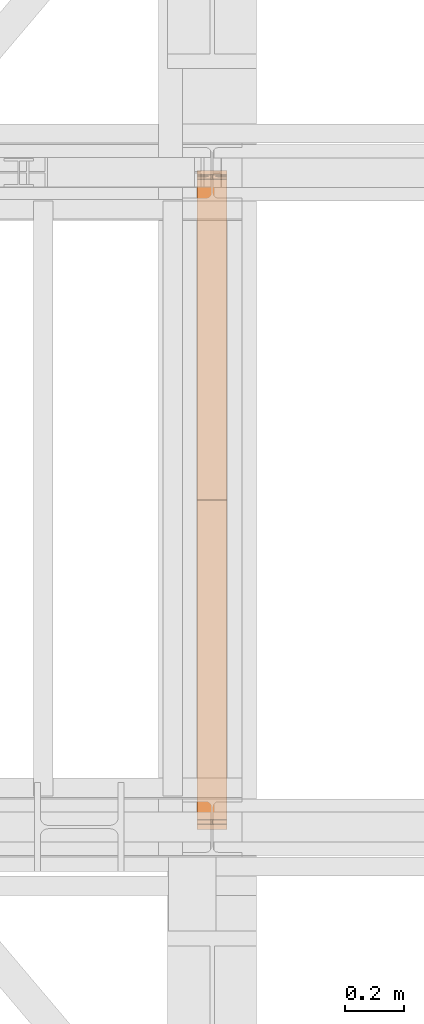
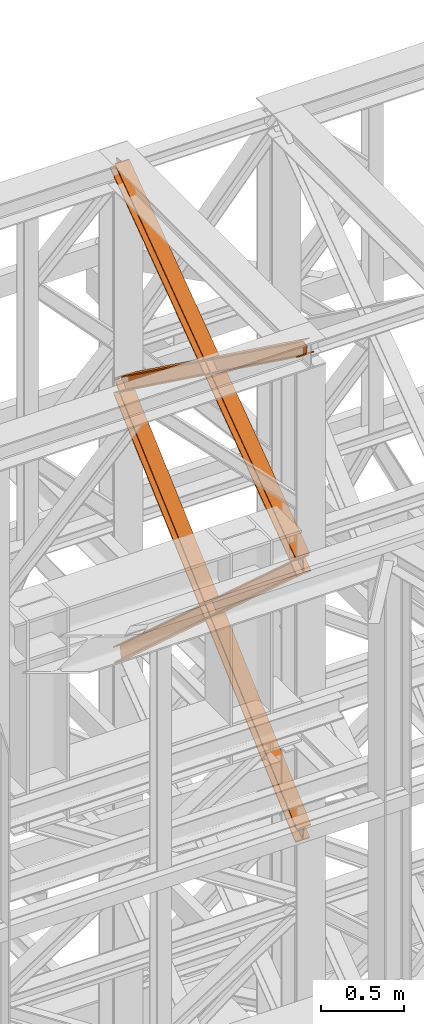
# One storey, part 158 of 208: 4 proxies.
"""IFC2X3 building model written with IfcOpenShell, lengths in millimetres."""

from ifc_helpers import new_model, entity, si_unit, converted_unit, frame, origin, origin_with_axes, place, context, subcontext, project, spatial, faceted_brep, element, save


model = new_model("IFC2X3")

# Units and contexts
model_context = context("Model", 3, precision=1e-05, world=origin())
plan_context = context("Plan", 3, precision=1e-05, world=origin())
body_context = subcontext(model_context, "Body", "Model", "MODEL_VIEW")
ifc_project = project(units=[si_unit("LENGTHUNIT", "METRE", prefix="MILLI"), converted_unit("PLANEANGLEUNIT", "DEGREE", entity("IfcPlaneAngleMeasure", 0.0174532925199433), si_unit("PLANEANGLEUNIT", "RADIAN"), dimensions=[0, 0, 0, 0, 0, 0, 0]), si_unit("AREAUNIT", "SQUARE_METRE"), si_unit("VOLUMEUNIT", "CUBIC_METRE")], contexts=[model_context, plan_context])

# Building, storey
building_placement = place(None, origin())
building = spatial("IfcBuilding", under=ifc_project, at=building_placement, CompositionType="COMPLEX")
storey_placement = place(building_placement, origin_with_axes())
storey = spatial("IfcBuildingStorey", under=building, at=storey_placement, Name="Geschoss", CompositionType="ELEMENT")

# Proxies
proxy_1_placement = place(storey_placement, frame((5442.709402308909, -16015.63876149258, 10682.68948145022), z_axis=(0.0, 0.0, 1.0), x_axis=(1.0, 0.0, 0.0)))
element("IfcBuildingElementProxy", 1, at=proxy_1_placement, inside=storey, context=body_context, shape_type="Brep", body=[
    faceted_brep([(100.0210796676656, 2245.689626284609, 118.5389832593155), (100.1143745484151, 56.20017042807194, 1708.580236273849), (100.1148393871226, 67.43957130666058, 1710.120789741106), (100.0220869572258, 2244.212677303514, 129.3143453983157), (100.0220869572258, 2244.212677303514, 129.3143453983157), (100.1148393871226, 67.43957130666058, 1710.120789741106), (0.1148394121519232, 67.45274636205431, 1710.122490249456), (0.02208754364073684, 2244.212677303513, 129.3256138365559), (0.02208754364073684, 2244.212677303513, 129.3256138365559), (0.1148394121519232, 67.45274636205431, 1710.122490249456), (0.1143745734407275, 56.21334548348023, 1708.581936782199), (0.02108025408597314, 2245.689626284609, 118.5502516975485), (0.02108025408597314, 2245.689626284609, 118.5502516975485), (0.1143745734407275, 56.21334548348023, 1708.581936782199), (47.61437456155181, 56.20708733215906, 1708.581129040735), (47.52107997553685, 2245.689626284611, 118.5448991893809), (47.52107997553685, 2245.689626284611, 118.5448991893809), (47.61437456155181, 56.20708733215906, 1708.581129040735), (47.61205046476789, 0.010082544398756, 1700.878361650326), (47.60701710203466, 7.394829104428936, 1647.001538883871), (47.51100702250551, 2260.459116064767, 10.79127802407129), (47.51100702250551, 2260.459116064767, 10.79127802407129), (47.60701710203466, 7.394829104428936, 1647.001538883871), (0.107017380585603, 7.394829104430755, 1647.006891392024), (0.01100730106008996, 2260.459116064769, 10.79663053222066), (0.01100730106008996, 2260.459116064769, 10.79663053222066), (0.107017380585603, 7.394829104430755, 1647.006891392024), (0.1060107062494353, 8.871778415476001, 1636.231526845748), (0.01000000000021828, 2261.936065039698, 0.02126843821861257), (0.01000000000021828, 2261.936065039698, 0.02126843821861257), (0.1060107062494353, 8.871778415476001, 1636.231526845748), (100.1060101198273, 8.871778415472363, 1636.220258407533), (100.0099994135744, 2261.936065039694, 0.01000000000021828), (100.0099994135744, 2261.936065039694, 0.01000000000021828), (100.1060101198273, 8.871778415472363, 1636.220258407533), (100.1070167941634, 7.394829104425298, 1646.995622953813), (100.0110067146379, 2260.459116064765, 10.78536209401318), (100.0110067146379, 2260.459116064765, 10.78536209401318), (100.1070167941634, 7.394829104425298, 1646.995622953813), (52.60701707271619, 7.394829104428936, 1647.000975461962), (52.51100699318704, 2260.459116064767, 10.79071460216255), (52.51100699318704, 2260.459116064767, 10.79071460216255), (52.60701707271619, 7.394829104428936, 1647.000975461962), (52.61205048734519, 0.01000000000021828, 1700.878355604191), (52.61437456030035, 56.20642857939311, 1708.581044015316), (52.52107994621292, 2245.689626284609, 118.5443357674758), (52.52107994621292, 2245.689626284609, 118.5443357674758), (52.61437456030035, 56.20642857939311, 1708.581044015316), (100.1143745484151, 56.20017042807194, 1708.580236273849), (100.0210796676656, 2245.689626284609, 118.5389832593155), (100.1143745484151, 56.20017042807194, 1708.580236273849), (52.61437456030035, 56.20642857939311, 1708.581044015316), (52.61205048734519, 0.01000000000021828, 1700.878355604191), (47.61205046476789, 0.010082544398756, 1700.878361650326), (47.61437456155181, 56.20708733215906, 1708.581129040735), (0.1143745734407275, 56.21334548348023, 1708.581936782199), (0.1148394121519232, 67.45274636205431, 1710.122490249456), (100.1148393871226, 67.43957130666058, 1710.120789741106), (47.61205046476789, 0.010082544398756, 1700.878361650326), (52.61205048734519, 0.01000000000021828, 1700.878355604191), (52.60701707271619, 7.394829104428936, 1647.000975461962), (100.1070167941634, 7.394829104425298, 1646.995622953813), (100.1060101198273, 8.871778415472363, 1636.220258407533), (0.1060107062494353, 8.871778415476001, 1636.231526845748), (0.107017380585603, 7.394829104430755, 1647.006891392024), (47.60701710203466, 7.394829104428936, 1647.001538883871), (100.0220869572258, 2244.212677303514, 129.3143453983157), (0.02208754364073684, 2244.212677303513, 129.3256138365559), (0.02108025408597314, 2245.689626284609, 118.5502516975485), (47.52107997553685, 2245.689626284611, 118.5448991893809), (47.51100702250551, 2260.459116064767, 10.79127802407129), (0.01100730106008996, 2260.459116064769, 10.79663053222066), (0.01000000000021828, 2261.936065039698, 0.02126843821861257), (100.0099994135744, 2261.936065039694, 0.01000000000021828), (100.0110067146379, 2260.459116064765, 10.78536209401318), (52.51100699318704, 2260.459116064767, 10.79071460216255), (52.52107994621292, 2245.689626284609, 118.5443357674758), (100.0210796676656, 2245.689626284609, 118.5389832593155)], [[[0, 1, 2, 3]], [[4, 5, 6, 7]], [[8, 9, 10, 11]], [[12, 13, 14, 15]], [[16, 17, 18, 19, 20]], [[21, 22, 23, 24]], [[25, 26, 27, 28]], [[29, 30, 31, 32]], [[33, 34, 35, 36]], [[37, 38, 39, 40]], [[41, 42, 43, 44, 45]], [[46, 47, 48, 49]], [[50, 51, 52, 53, 54, 55, 56, 57]], [[58, 59, 60, 61, 62, 63, 64, 65]], [[66, 67, 68, 69, 70, 71, 72, 73, 74, 75, 76, 77]]], orient=[[False], [False], [False], [False], [False], [False], [False], [False], [False], [False], [False], [False], [False], [False], [False]]),
])
proxy_2_placement = place(storey_placement, frame((5442.729181833694, -15971.44366069647, 10682.68296591904), z_axis=(0.0, 0.0, 1.0), x_axis=(1.0, 0.0, 0.0)))
element("IfcBuildingElementProxy", 2, at=proxy_2_placement, inside=storey, context=body_context, shape_type="Brep", body=[
    faceted_brep([(100.0217932552368, 17.74853331263148, 129.3267546407205), (100.0912677831911, 2190.182945540866, 1706.987836358048), (100.0906922275608, 2201.421092011329, 1705.446286432978), (100.0208104383473, 16.27032220023102, 118.5503583986774), (0.02179387014803069, 17.74853331263148, 129.3386776252864), (0.09126795233532903, 2190.169006714281, 1706.989636715169), (100.0912677831911, 2190.182945540866, 1706.987836358048), (100.0217932552368, 17.74853331263148, 129.3267546407205), (0.0208110532585124, 16.27032220022738, 118.5622813832288), (0.09069239670316165, 2201.407153184735, 1705.448086790095), (0.09126795233532903, 2190.169006714281, 1706.989636715169), (0.02179387014803069, 17.74853331263148, 129.3386776252864), (47.52081076117611, 16.2703222002292, 118.5566179655598), (47.59069231636022, 2201.413774127363, 1705.447231620465), (0.09069239670316165, 2201.407153184735, 1705.448086790095), (0.0208110532585124, 16.27032220022738, 118.5622813832288), (47.51098253605778, 1.488211106367089, 10.79265576491343), (47.58304941302777, 2254.773823250514, 1647.169314498546), (47.58760831105064, 2261.634760381639, 1697.186647271237), (47.59069231636022, 2201.413774127363, 1705.447231620465), (47.52081076117611, 16.2703222002292, 118.5566179655598), (0.01098282814200502, 1.488211106363451, 10.79831918255331), (0.08304970511198917, 2254.773823250511, 1647.174977916204), (47.58304941302777, 2254.773823250514, 1647.169314498546), (47.51098253605778, 1.488211106367089, 10.79265576491343), (0.01000000000021828, 0.01000000000021828, 0.02192298452973773), (0.08206748974225775, 2253.295611815232, 1636.398579320261), (0.08304970511198917, 2254.773823250511, 1647.174977916204), (0.01098282814200502, 1.488211106363451, 10.79831918255331), (100.0099993850836, 0.01000000000567525, 0.01000000000021828), (100.0820668748293, 2253.29561181524, 1636.386656335728), (0.08206748974225775, 2253.295611815232, 1636.398579320261), (0.01000000000021828, 0.01000000000021828, 0.02192298452973773), (100.010982213229, 1.488211106370727, 10.78639619803107), (100.0830490901917, 2254.773823250516, 1647.163054931671), (100.0820668748293, 2253.29561181524, 1636.386656335728), (100.0099993850836, 0.01000000000567525, 0.01000000000021828), (52.51098250530595, 1.48821110636527, 10.79205961566731), (52.58304938227957, 2254.773823250514, 1647.168718349318), (100.0830490901917, 2254.773823250516, 1647.163054931671), (100.010982213229, 1.488211106370727, 10.78639619803107), (52.52081073042791, 16.27032220022738, 118.5560218163319), (52.59069230790374, 2201.414471068691, 1705.447141602608), (52.58760833413726, 2261.634841397497, 1697.186641740611), (52.58304938227957, 2254.773823250514, 1647.168718349318), (52.51098250530595, 1.48821110636527, 10.79205961566731), (100.0208104383473, 16.27032220023102, 118.5503583986774), (100.0906922275608, 2201.421092011329, 1705.446286432978), (52.59069230790374, 2201.414471068691, 1705.447141602608), (52.52081073042791, 16.27032220022738, 118.5560218163319), (100.0912677831911, 2190.182945540866, 1706.987836358048), (0.09126795233532903, 2190.169006714281, 1706.989636715169), (0.09069239670316165, 2201.407153184735, 1705.448086790095), (47.59069231636022, 2201.413774127363, 1705.447231620465), (47.58760831105064, 2261.634760381639, 1697.186647271237), (52.58760833413726, 2261.634841397497, 1697.186641740611), (52.59069230790374, 2201.414471068691, 1705.447141602608), (100.0906922275608, 2201.421092011329, 1705.446286432978), (47.58760831105064, 2261.634760381639, 1697.186647271237), (47.58304941302777, 2254.773823250514, 1647.169314498546), (0.08304970511198917, 2254.773823250511, 1647.174977916204), (0.08206748974225775, 2253.295611815232, 1636.398579320261), (100.0820668748293, 2253.29561181524, 1636.386656335728), (100.0830490901917, 2254.773823250516, 1647.163054931671), (52.58304938227957, 2254.773823250514, 1647.168718349318), (52.58760833413726, 2261.634841397497, 1697.186641740611), (100.0208104383473, 16.27032220023102, 118.5503583986774), (52.52081073042791, 16.27032220022738, 118.5560218163319), (52.51098250530595, 1.48821110636527, 10.79205961566731), (100.010982213229, 1.488211106370727, 10.78639619803107), (100.0099993850836, 0.01000000000567525, 0.01000000000021828), (0.01000000000021828, 0.01000000000021828, 0.02192298452973773), (0.01098282814200502, 1.488211106363451, 10.79831918255331), (47.51098253605778, 1.488211106367089, 10.79265576491343), (47.52081076117611, 16.2703222002292, 118.5566179655598), (0.0208110532585124, 16.27032220022738, 118.5622813832288), (0.02179387014803069, 17.74853331263148, 129.3386776252864), (100.0217932552368, 17.74853331263148, 129.3267546407205)], [[[0, 1, 2, 3]], [[4, 5, 6, 7]], [[8, 9, 10, 11]], [[12, 13, 14, 15]], [[16, 17, 18, 19, 20]], [[21, 22, 23, 24]], [[25, 26, 27, 28]], [[29, 30, 31, 32]], [[33, 34, 35, 36]], [[37, 38, 39, 40]], [[41, 42, 43, 44, 45]], [[46, 47, 48, 49]], [[50, 51, 52, 53, 54, 55, 56, 57]], [[58, 59, 60, 61, 62, 63, 64, 65]], [[66, 67, 68, 69, 70, 71, 72, 73, 74, 75, 76, 77]]], orient=[[False], [False], [False], [False], [False], [False], [False], [False], [False], [False], [False], [False], [False], [False], [False]]),
])
proxy_3_placement = place(storey_placement, frame((5442.676947659522, -15970.94025142175, 8709.664099392032), z_axis=(0.0, 0.0, 1.0), x_axis=(1.0, 0.0, 0.0)))
element("IfcBuildingElementProxy", 3, at=proxy_3_placement, inside=storey, context=body_context, shape_type="Brep", body=[
    faceted_brep([(100.0233874223195, 2202.524047252906, 1969.026231437971), (100.204135948361, 16.74193427489081, 0.02100513656296243), (100.2031119106669, 15.34760641933463, 9.331797992270367), (100.0223627570795, 2201.129719715085, 1978.337022171885), (0.02338802788472094, 2202.524047252906, 1969.015226301408), (0.2041365539262188, 16.74193427489081, 0.01000000000021828), (100.204135948361, 16.74193427489081, 0.02100513656296243), (100.0233874223195, 2202.524047252906, 1969.026231437971), (0.02236336264650163, 2201.129719715083, 1978.32601703533), (0.2031125162320677, 15.34760641933463, 9.320792855700347), (0.2041365539262188, 16.74193427489081, 0.01000000000021828), (0.02338802788472094, 2202.524047252906, 1969.015226301408), (47.52236307500243, 2201.129719715083, 1978.331244475192), (47.703112228588, 15.34760641933463, 9.326020295562557), (0.2031125162320677, 15.34760641933463, 9.320792855700347), (0.02236336264650163, 2201.129719715083, 1978.32601703533), (47.51211642258568, 2187.186444336861, 2071.439151814395), (47.69287186516885, 1.404327856926102, 102.4339488982641), (47.703112228588, 15.34760641933463, 9.326020295562557), (47.52236307500243, 2201.129719715083, 1978.331244475192), (0.0110594602265337, 2197.850904391578, 2081.040801967907), (0.01123343514518638, 2196.096022801514, 2079.459950003524), (29.30670605184969, 2196.096022801514, 2079.463174010305), (38.62248918838486, 2197.75725418804, 2080.960688188874), (38.72759933923771, 2197.85090439158, 2081.04506277602), (47.51211642258568, 2187.186444336861, 2071.439151814395), (0.0121167102297477, 2187.186444336861, 2071.433924374533), (0.1928721528147435, 1.404327856924283, 102.4287214583947), (47.69287186516885, 1.404327856926102, 102.4339488982641), (0.01000000000021828, 2196.807553171771, 2090.667763094707), (0.01020876990332909, 2194.701695263691, 2088.770740737438), (0.01123343514518638, 2196.096022801514, 2079.459950003524), (0.0110594602265337, 2197.850904391578, 2081.040801967907), (0.0121167102297477, 2187.186444336861, 2071.433924374533), (0.01109204498970939, 2185.792116799039, 2080.744715108447), (0.1918481178254297, 0.00999999999839929, 111.7395143232407), (0.1928721528147435, 1.404327856924283, 102.4287214583947), (100.0099993944386, 2196.80755317177, 2090.67876823127), (100.0102081643418, 2194.701695263691, 2088.781745874001), (71.80672165016404, 2194.701695263691, 2088.778642041782), (62.49088072881023, 2196.362926650216, 2090.274105784663), (61.99182992716487, 2196.80755317177, 2090.674584279774), (0.01109204498970939, 2185.792116799039, 2080.744715108447), (100.0110914394281, 2185.792116799039, 2080.755720245017), (100.1918475122639, 0.00999999999839929, 111.7505194598034), (0.1918481178254297, 0.00999999999839929, 111.7395143232407), (0.01020876990332909, 2194.701695263691, 2088.770740737438), (0.01000000000021828, 2196.807553171771, 2090.667763094707), (39.12153594998199, 2196.807553171771, 2090.672067372672), (38.62250061437408, 2196.362926650216, 2090.271479036817), (29.3067174778389, 2194.701695263691, 2088.773964858256), (100.0110588546631, 2197.85090439158, 2081.051807104463), (100.01123282958, 2196.096022801514, 2079.470955140079), (100.0102081643418, 2194.701695263691, 2088.781745874001), (100.0099993944386, 2196.80755317177, 2090.67876823127), (100.0110914394281, 2185.792116799039, 2080.755720245017), (100.0121161046682, 2187.186444336861, 2071.444929511088), (100.1928715472459, 1.404327856926102, 102.4397265949574), (100.1918475122639, 0.00999999999839929, 111.7505194598034), (52.5121163923086, 2187.186444336861, 2071.439702071226), (52.69287183489359, 1.404327856924283, 102.4344991550879), (100.1928715472459, 1.404327856926102, 102.4397265949574), (100.0121161046682, 2187.186444336861, 2071.444929511088), (71.80671022417482, 2196.096022801516, 2079.467851193831), (100.01123282958, 2196.096022801514, 2079.470955140079), (100.0110588546631, 2197.85090439158, 2081.051807104463), (62.38575589440734, 2197.85090439158, 2081.047666388475), (62.49086930282101, 2197.75725418804, 2080.963314936713), (52.52236304472172, 2201.129719715083, 1978.331794732023), (52.7031121983091, 15.34760641933463, 9.326570552393605), (52.69287183489359, 1.404327856924283, 102.4344991550879), (52.5121163923086, 2187.186444336861, 2071.439702071226), (100.0223627570795, 2201.129719715085, 1978.337022171885), (100.2031119106669, 15.34760641933463, 9.331797992270367), (52.7031121983091, 15.34760641933463, 9.326570552393605), (52.52236304472172, 2201.129719715083, 1978.331794732023), (62.38575589440734, 2197.85090439158, 2081.047666388475), (100.0110588546631, 2197.85090439158, 2081.051807104463), (100.0099993944386, 2196.80755317177, 2090.67876823127), (61.99182992716487, 2196.80755317177, 2090.674584279774), (39.12153594998199, 2196.807553171771, 2090.672067372672), (0.01000000000021828, 2196.807553171771, 2090.667763094707), (0.0110594602265337, 2197.850904391578, 2081.040801967907), (38.72759933923771, 2197.85090439158, 2081.04506277602), (62.49086930282101, 2197.75725418804, 2080.963314936713), (62.38575589440734, 2197.85090439158, 2081.047666388475), (61.99182992716487, 2196.80755317177, 2090.674584279774), (62.49088072881023, 2196.362926650216, 2090.274105784663), (62.49088072881023, 2196.362926650216, 2090.274105784663), (71.80672165016404, 2194.701695263691, 2088.778642041782), (71.80671022417482, 2196.096022801516, 2079.467851193831), (62.49086930282101, 2197.75725418804, 2080.963314936713), (71.80672165016404, 2194.701695263691, 2088.778642041782), (100.0102081643418, 2194.701695263691, 2088.781745874001), (100.01123282958, 2196.096022801514, 2079.470955140079), (71.80671022417482, 2196.096022801516, 2079.467851193831), (100.0223627570795, 2201.129719715085, 1978.337022171885), (52.52236304472172, 2201.129719715083, 1978.331794732023), (52.5121163923086, 2187.186444336861, 2071.439702071226), (100.0121161046682, 2187.186444336861, 2071.444929511088), (100.0110914394281, 2185.792116799039, 2080.755720245017), (0.01109204498970939, 2185.792116799039, 2080.744715108447), (0.0121167102297477, 2187.186444336861, 2071.433924374533), (47.51211642258568, 2187.186444336861, 2071.439151814395), (47.52236307500243, 2201.129719715083, 1978.331244475192), (0.02236336264650163, 2201.129719715083, 1978.32601703533), (0.02338802788472094, 2202.524047252906, 1969.015226301408), (100.0233874223195, 2202.524047252906, 1969.026231437971), (29.30670605184969, 2196.096022801514, 2079.463174010305), (0.01123343514518638, 2196.096022801514, 2079.459950003524), (0.01020876990332909, 2194.701695263691, 2088.770740737438), (29.3067174778389, 2194.701695263691, 2088.773964858256), (29.3067174778389, 2194.701695263691, 2088.773964858256), (38.62250061437408, 2196.362926650216, 2090.271479036817), (38.62248918838486, 2197.75725418804, 2080.960688188874), (29.30670605184969, 2196.096022801514, 2079.463174010305), (38.62250061437408, 2196.362926650216, 2090.271479036817), (39.12153594998199, 2196.807553171771, 2090.672067372672), (38.72759933923771, 2197.85090439158, 2081.04506277602), (38.62248918838486, 2197.75725418804, 2080.960688188874), (100.204135948361, 16.74193427489081, 0.02100513656296243), (0.2041365539262188, 16.74193427489081, 0.01000000000021828), (0.2031125162320677, 15.34760641933463, 9.320792855700347), (47.703112228588, 15.34760641933463, 9.326020295562557), (47.69287186516885, 1.404327856926102, 102.4339488982641), (0.1928721528147435, 1.404327856924283, 102.4287214583947), (0.1918481178254297, 0.00999999999839929, 111.7395143232407), (100.1918475122639, 0.00999999999839929, 111.7505194598034), (100.1928715472459, 1.404327856926102, 102.4397265949574), (52.69287183489359, 1.404327856924283, 102.4344991550879), (52.7031121983091, 15.34760641933463, 9.326570552393605), (100.2031119106669, 15.34760641933463, 9.331797992270367)], [[[0, 1, 2, 3]], [[4, 5, 6, 7]], [[8, 9, 10, 11]], [[12, 13, 14, 15]], [[16, 17, 18, 19]], [[20, 21, 22, 23, 24]], [[25, 26, 27, 28]], [[29, 30, 31, 32]], [[33, 34, 35, 36]], [[37, 38, 39, 40, 41]], [[42, 43, 44, 45]], [[46, 47, 48, 49, 50]], [[51, 52, 53, 54]], [[55, 56, 57, 58]], [[59, 60, 61, 62]], [[63, 64, 65, 66, 67]], [[68, 69, 70, 71]], [[72, 73, 74, 75]], [[76, 77, 78, 79]], [[80, 81, 82, 83]], [[84, 85, 86, 87]], [[88, 89, 90, 91]], [[92, 93, 94, 95]], [[96, 97, 98, 99, 100, 101, 102, 103, 104, 105, 106, 107]], [[108, 109, 110, 111]], [[112, 113, 114, 115]], [[116, 117, 118, 119]], [[120, 121, 122, 123, 124, 125, 126, 127, 128, 129, 130, 131]]], orient=[[False], [False], [False], [False], [False], [False], [False], [False], [False], [False], [False], [False], [False], [False], [False], [False], [False], [False], [False], [False], [False], [False], [False], [False], [False], [False], [False], [False]]),
])
proxy_4_placement = place(storey_placement, frame((5442.73408746112, -15954.28145682049, 8709.631705441292), z_axis=(0.0, 0.0, 1.0), x_axis=(1.0, 0.0, 0.0)))
element("IfcBuildingElementProxy", 4, at=proxy_4_placement, inside=storey, context=body_context, shape_type="Brep", body=[
    faceted_brep([(100.0202537490113, 1.404418357440591, 1976.169685278082), (100.1537894349167, 2184.74959498962, 9.331916248220296), (100.1547211341531, 2183.35672227913, 0.0197810693334759), (100.0211859525844, 0.01154596052219858, 1966.857552195595), (100.0211859525844, 0.01154596052219858, 1966.857552195595), (100.1547211341531, 2183.35672227913, 0.0197810693334759), (0.1547216244507581, 2183.355176318608, 0.01000000000021828), (0.02118644288202631, 0.01000000000021828, 1966.847771126266), (0.02118644288202631, 0.01000000000021828, 1966.847771126266), (0.1547216244507581, 2183.355176318608, 0.01000000000021828), (0.1537899252161878, 2184.748049029098, 9.322135178887038), (0.02025423930899706, 1.40287239691861, 1976.159904208749), (0.02025423930899706, 1.40287239691861, 1976.159904208749), (0.1537899252161878, 2184.748049029098, 9.322135178887038), (47.65378969232734, 2184.748783360346, 9.326781186826338), (47.52025400642015, 1.403606728164959, 1976.164550216681), (47.52025400642015, 1.403606728164959, 1976.164550216681), (47.65378969232734, 2184.748783360346, 9.326781186826338), (47.64447271073732, 2198.677510471935, 102.4481330204089), (47.51093197068258, 15.33233069734524, 2069.285881041526), (47.51093197068258, 15.33233069734524, 2069.285881041526), (47.64447271073732, 2198.677510471935, 102.4481330204089), (0.1444729436279886, 2198.676776140686, 102.4434870124769), (0.01093220357506652, 15.33159636609526, 2069.281235033586), (0.01093220357506652, 15.33159636609526, 2069.281235033586), (0.1444729436279886, 2198.676776140686, 102.4434870124769), (0.1435412465452828, 2200.069648852516, 111.7556222003168), (0.01000000000021828, 16.72446876301547, 2078.593368116077), (0.01000000000021828, 16.72446876301547, 2078.593368116077), (0.1435412465452828, 2200.069648852516, 111.7556222003168), (100.1435407562476, 2200.071194813039, 111.7654032696537), (100.0099995097044, 16.72601472353745, 2078.603149185414), (100.0099995097044, 16.72601472353745, 2078.603149185414), (100.1435407562476, 2200.071194813039, 111.7654032696537), (100.1444724533303, 2198.67832210121, 102.4532680818102), (100.0109317132756, 15.33314232661905, 2069.29101610293), (100.0109317132756, 15.33314232661905, 2069.29101610293), (100.1444724533303, 2198.67832210121, 102.4532680818102), (52.64447268622098, 2198.677587769962, 102.4486220738781), (52.51093194616988, 15.33240799537089, 2069.286370094991), (52.51093194616988, 15.33240799537089, 2069.286370094991), (52.64447268622098, 2198.677587769962, 102.4486220738781), (52.653789667811, 2184.748860658372, 9.327270240288271), (52.52025398190563, 1.403684026192423, 1976.165039270154), (52.52025398190563, 1.403684026192423, 1976.165039270154), (52.653789667811, 2184.748860658372, 9.327270240288271), (100.1537894349167, 2184.74959498962, 9.331916248220296), (100.0202537490113, 1.404418357440591, 1976.169685278082), (100.0211859525844, 0.01154596052219858, 1966.857552195595), (0.02118644288202631, 0.01000000000021828, 1966.847771126266), (0.02025423930899706, 1.40287239691861, 1976.159904208749), (47.52025400642015, 1.403606728164959, 1976.164550216681), (47.51093197068258, 15.33233069734524, 2069.285881041526), (0.01093220357506652, 15.33159636609526, 2069.281235033586), (0.01000000000021828, 16.72446876301547, 2078.593368116077), (100.0099995097044, 16.72601472353745, 2078.603149185414), (100.0109317132756, 15.33314232661905, 2069.29101610293), (52.51093194616988, 15.33240799537089, 2069.286370094991), (52.52025398190563, 1.403684026192423, 1976.165039270154), (100.0202537490113, 1.404418357440591, 1976.169685278082), (100.1537894349167, 2184.74959498962, 9.331916248220296), (52.653789667811, 2184.748860658372, 9.327270240288271), (52.64447268622098, 2198.677587769962, 102.4486220738781), (100.1444724533303, 2198.67832210121, 102.4532680818102), (100.1435407562476, 2200.071194813039, 111.7654032696537), (0.1435412465452828, 2200.069648852516, 111.7556222003168), (0.1444729436279886, 2198.676776140686, 102.4434870124769), (47.64447271073732, 2198.677510471935, 102.4481330204089), (47.65378969232734, 2184.748783360346, 9.326781186826338), (0.1537899252161878, 2184.748049029098, 9.322135178887038), (0.1547216244507581, 2183.355176318608, 0.01000000000021828), (100.1547211341531, 2183.35672227913, 0.0197810693334759)], [[[0, 1, 2, 3]], [[4, 5, 6, 7]], [[8, 9, 10, 11]], [[12, 13, 14, 15]], [[16, 17, 18, 19]], [[20, 21, 22, 23]], [[24, 25, 26, 27]], [[28, 29, 30, 31]], [[32, 33, 34, 35]], [[36, 37, 38, 39]], [[40, 41, 42, 43]], [[44, 45, 46, 47]], [[48, 49, 50, 51, 52, 53, 54, 55, 56, 57, 58, 59]], [[60, 61, 62, 63, 64, 65, 66, 67, 68, 69, 70, 71]]], orient=[[False], [False], [False], [False], [False], [False], [False], [False], [False], [False], [False], [False], [False], [False]]),
])

save(model, "model.ifc")
